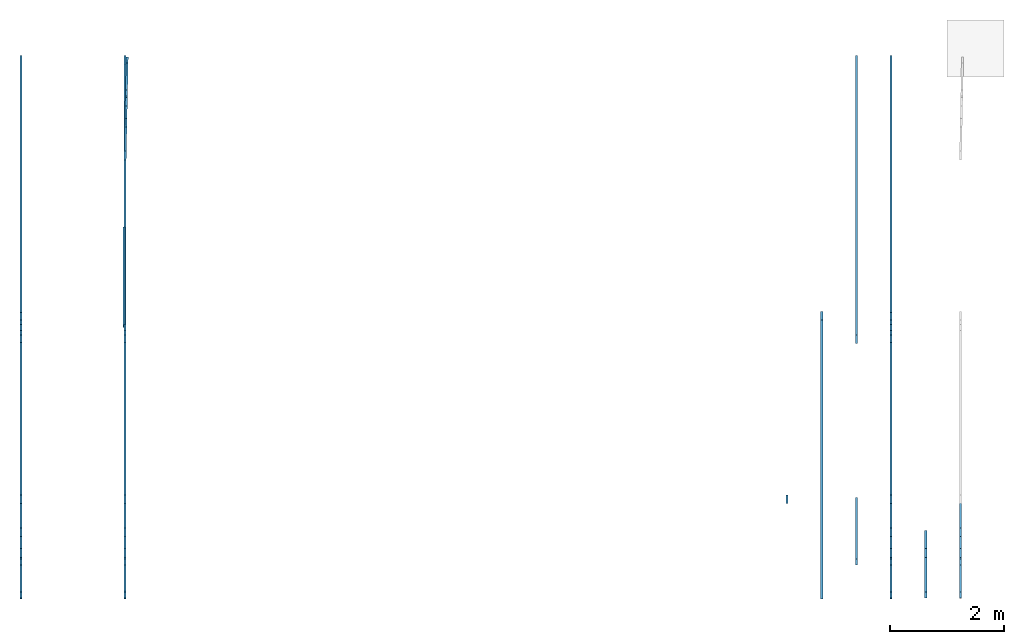
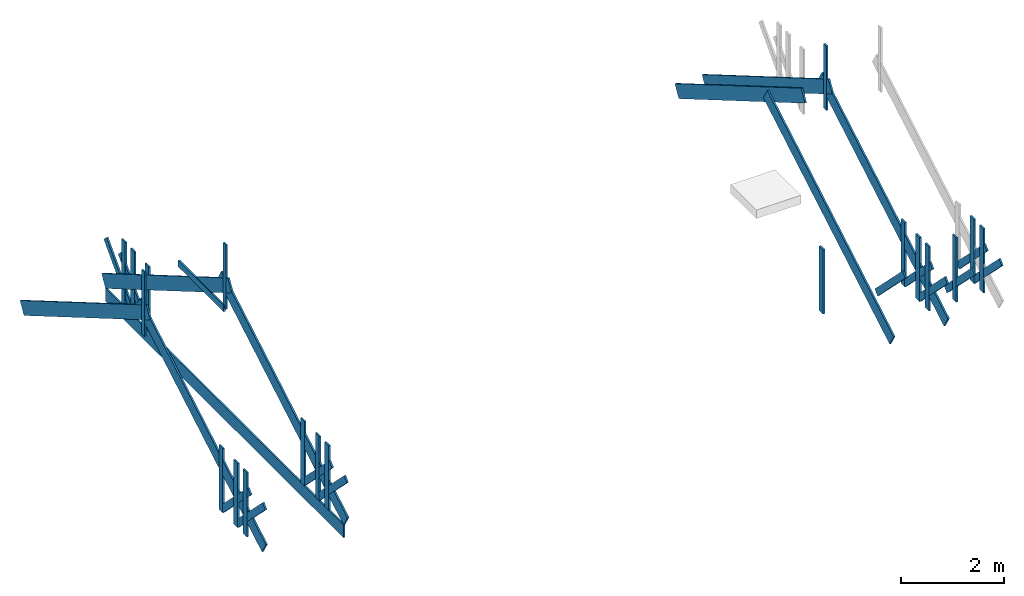
# One storey, part 1 of 2: 44 members, 2 elements without a shape of their own.
"""IFC4 building model written with IfcOpenShell, lengths in inches."""

from ifc_helpers import new_model, entity, si_unit, converted_unit, frame, origin_with_axes, origin_2d_with_axis, place, context, subcontext, project, spatial, indexed_curve, outline, extrude, material, layer, layer_set, layer_usage, type_object, element, aggregate, save


model = new_model("IFC4")

# Units and contexts
model_context = context("Model", 3, precision=1e-05, world=origin_with_axes())
plan_context = context("Plan", 2, precision=1e-05, world=origin_2d_with_axis())
body_context = subcontext(model_context, "Body", "Model", "MODEL_VIEW")
ifc_project = project(units=[converted_unit("PLANEANGLEUNIT", "degree", entity("IfcReal", 0.0174532925199433), si_unit("PLANEANGLEUNIT", "RADIAN"), dimensions=[0, 0, 0, 0, 0, 0, 0]), converted_unit("AREAUNIT", "square inch", entity("IfcReal", 0.0006452), si_unit("AREAUNIT", "SQUARE_METRE"), dimensions=[2, 0, 0, 0, 0, 0, 0]), converted_unit("LENGTHUNIT", "inch", entity("IfcReal", 0.0254), si_unit("LENGTHUNIT", "METRE"), dimensions=[1, 0, 0, 0, 0, 0, 0]), converted_unit("VOLUMEUNIT", "cubic inch", entity("IfcReal", 1.639e-05), si_unit("VOLUMEUNIT", "CUBIC_METRE"), dimensions=[3, 0, 0, 0, 0, 0, 0])], contexts=[model_context, plan_context])

# Site, building, storey
site_placement = place(None, origin_with_axes())
site = spatial("IfcSite", under=ifc_project, at=site_placement)
building_placement = place(site_placement, frame((0.0, 0.0, 109.012492998378), z_axis=(0.0, 0.0, 1.0), x_axis=(1.0, 0.0, 0.0)))
building = spatial("IfcBuilding", under=site, at=building_placement, Name="Building")
storey_placement = place(building_placement, frame((0.0, 0.0, -109.012492998378), z_axis=(0.0, 0.0, 1.0), x_axis=(1.0, 0.0, 0.0)))
storey = spatial("IfcBuildingStorey", under=building, at=storey_placement, Name="Roof")

# Assembly, members
assembly_1_placement = place(storey_placement, frame((53.5001435617762, -175.939563691147, 109.012492998378), z_axis=(0.0, 0.0, 1.0), x_axis=(1.0, 0.0, 0.0)))
assembly_1 = element("IfcElementAssembly", 1, at=assembly_1_placement, inside=storey, Name="QueenTruss", PredefinedType="TRUSS")
ifc_material = material(Name="Default")
ifc_layer_1 = layer(ifc_material, 1.5)
ifc_layer_set_1 = layer_set([ifc_layer_1])
ifc_layer_usage_1 = layer_usage(ifc_layer_set_1, "AXIS2", "POSITIVE", 0.0)
member_type_1 = type_object("IfcMemberType", Name="2x12 wood rafter", PredefinedType="RAFTER", material=ifc_layer_set_1)
member_1_placement = place(assembly_1_placement, frame((1.4999344592958, -181.939526805727, 12.0000013216274), z_axis=(2.75442979535967e-09, -0.504527628421783, 0.863395571708679), x_axis=(5.79808386191871e-07, 0.863395571708679, 0.504527628421783)))
member_1 = element("IfcMember", 2, at=member_1_placement, type_object=member_type_1, material=ifc_layer_usage_1, Name="Member", PredefinedType="NOTDEFINED", context=body_context, shape_type="SweptSolid", body=[
    extrude(outline(indexed_curve([(0.0, 0.0), (0.0, 1.5), (223.635576889592, 1.5), (223.635576889592, 0.0), (0.0, 0.0)], self_intersect=False)), origin_with_axes(), (0.0, 0.0, 1.0), 12.0),
])
ifc_layer_usage_2 = layer_usage(ifc_layer_set_1, "AXIS2", "POSITIVE", 0.0)
member_2_placement = place(assembly_1_placement, frame((3.75462329293799e-05, 181.939563765301, 12.0000013216274), z_axis=(-5.96369176264488e-08, 0.504527628421783, 0.863395571708679), x_axis=(-1.06698792023963e-06, -0.863395571708679, 0.504527628421783)))
member_2 = element("IfcMember", 3, at=member_2_placement, type_object=member_type_1, material=ifc_layer_usage_2, Name="Member", PredefinedType="NOTDEFINED", context=body_context, shape_type="SweptSolid", body=[
    extrude(outline(indexed_curve([(0.0, 0.0), (0.0, 1.5), (223.635576889743, 1.5), (223.635576889743, 0.0), (0.0, 0.0)], self_intersect=False)), origin_with_axes(), (0.0, 0.0, 1.0), 12.0),
])
ifc_layer_usage_3 = layer_usage(ifc_layer_set_1, "AXIS2", "POSITIVE", 0.0)
member_3_placement = place(assembly_1_placement, frame((-71.9998976377052, 181.939563765301, 12.000001321627), z_axis=(-5.96369176264488e-08, 0.504527628421783, 0.863395571708679), x_axis=(-1.06698792023963e-06, -0.863395571708679, 0.504527628421783)))
member_3 = element("IfcMember", 4, at=member_3_placement, type_object=member_type_1, material=ifc_layer_usage_3, Name="Member", PredefinedType="NOTDEFINED", context=body_context, shape_type="SweptSolid", body=[
    extrude(outline(indexed_curve([(0.0, 0.0), (0.0, 1.5), (223.635576889743, 1.5), (223.635576889743, 0.0), (0.0, 0.0)], self_intersect=False)), origin_with_axes(), (0.0, 0.0, 1.0), 12.0),
])
ifc_layer_usage_4 = layer_usage(ifc_layer_set_1, "AXIS2", "POSITIVE", 0.0)
member_4_placement = place(assembly_1_placement, frame((-70.5000007246422, -181.939526805727, 12.000001321627), z_axis=(2.75442979535967e-09, -0.504527628421783, 0.863395571708679), x_axis=(5.79808386191871e-07, 0.863395571708679, 0.504527628421783)))
member_4 = element("IfcMember", 5, at=member_4_placement, type_object=member_type_1, material=ifc_layer_usage_4, Name="Member", PredefinedType="NOTDEFINED", context=body_context, shape_type="SweptSolid", body=[
    extrude(outline(indexed_curve([(0.0, 0.0), (0.0, 1.5), (223.635576889592, 1.5), (223.635576889592, 0.0), (0.0, 0.0)], self_intersect=False)), origin_with_axes(), (0.0, 0.0, 1.0), 12.0),
])

assembly_2_placement = place(storey_placement, origin_with_axes())
assembly_2 = element("IfcElementAssembly", 6, at=assembly_2_placement, inside=storey, Name="Assembly", PredefinedType="NOTDEFINED")
ifc_layer_usage_5 = layer_usage(ifc_layer_set_1, "AXIS2", "POSITIVE", 0.0)
member_5_placement = place(assembly_2_placement, frame((559.49999591497, 6.00000007415381, 121.012494320006), z_axis=(-5.96369176264488e-08, 0.504527628421783, 0.863395571708679), x_axis=(-1.06698792023963e-06, -0.863395571708679, 0.504527628421783)))
member_5 = element("IfcMember", 7, at=member_5_placement, type_object=member_type_1, material=ifc_layer_usage_5, Name="Member", PredefinedType="NOTDEFINED", context=body_context, shape_type="SweptSolid", body=[
    extrude(outline(indexed_curve([(0.0, 0.0), (0.0, 1.5), (223.635576889743, 1.5), (223.635576889743, 0.0), (0.0, 0.0)], self_intersect=False)), origin_with_axes(), (0.0, 0.0, 1.0), 12.0),
])
ifc_layer_usage_6 = layer_usage(ifc_layer_set_1, "AXIS2", "POSITIVE", 0.0)
member_6_placement = place(assembly_2_placement, frame((536.999890184778, -357.879090496874, 121.012494320006), z_axis=(2.75442979535967e-09, -0.504527628421783, 0.863395571708679), x_axis=(5.79808386191871e-07, 0.863395571708679, 0.504527628421783)))
member_6 = element("IfcMember", 8, at=member_6_placement, type_object=member_type_1, material=ifc_layer_usage_6, Name="Member", PredefinedType="NOTDEFINED", context=body_context, shape_type="SweptSolid", body=[
    extrude(outline(indexed_curve([(0.0, 0.0), (0.0, 1.5), (223.635576889592, 1.5), (223.635576889592, 0.0), (0.0, 0.0)], self_intersect=False)), origin_with_axes(), (0.0, 0.0, 1.0), 12.0),
])

# Member
ifc_layer_usage_7 = layer_usage(ifc_layer_set_1, "AXIS2", "POSITIVE", 0.0)
member_7_placement = place(assembly_1_placement, frame((529.999930088914, 181.939563765301, 12.0000013216274), z_axis=(-5.96369176264488e-08, 0.504527628421783, 0.863395571708679), x_axis=(-1.06698792023963e-06, -0.863395571708679, 0.504527628421783)))
member_7 = element("IfcMember", 9, at=member_7_placement, type_object=member_type_1, material=ifc_layer_usage_7, Name="Member", PredefinedType="NOTDEFINED", context=body_context, shape_type="SweptSolid", body=[
    extrude(outline(indexed_curve([(0.0, 0.0), (0.0, 1.5), (223.635576889743, 1.5), (223.635576889743, 0.0), (0.0, 0.0)], self_intersect=False)), origin_with_axes(), (0.0, 0.0, 1.0), 12.0),
])

ifc_layer_usage_8 = layer_usage(ifc_layer_set_1, "AXIS2", "POSITIVE", 0.0)
member_8_placement = place(assembly_1_placement, frame((531.499827001977, -181.939526805727, 12.0000013216274), z_axis=(2.75442979535967e-09, -0.504527628421783, 0.863395571708679), x_axis=(5.79808386191871e-07, 0.863395571708679, 0.504527628421783)))
member_8 = element("IfcMember", 10, at=member_8_placement, type_object=member_type_1, material=ifc_layer_usage_8, Name="Member", PredefinedType="NOTDEFINED", context=body_context, shape_type="SweptSolid", body=[
    extrude(outline(indexed_curve([(0.0, 0.0), (0.0, 1.5), (223.635576889592, 1.5), (223.635576889592, 0.0), (0.0, 0.0)], self_intersect=False)), origin_with_axes(), (0.0, 0.0, 1.0), 12.0),
])

ifc_layer_2 = layer(ifc_material, 1.5, ventilated=False, Name="2x4 wood member")
ifc_layer_set_2 = layer_set([ifc_layer_2], Name="2x4 wood member")
ifc_layer_usage_9 = layer_usage(ifc_layer_set_2, "AXIS2", "POSITIVE", 0.0)
member_type_2 = type_object("IfcMemberType", Name="2x4 wood member", PredefinedType="NOTDEFINED", material=ifc_layer_set_2)
member_9_placement = place(assembly_1_placement, frame((1.50008464422752, 2.00001273568221, 104.000014582957), z_axis=(4.37113882867379e-08, -1.0, -8.51092183247427e-15), x_axis=(1.94707183709397e-07, 0.0, 1.0)))
member_9 = element("IfcMember", 11, at=member_9_placement, type_object=member_type_2, material=ifc_layer_usage_9, Name="Member", PredefinedType="NOTDEFINED", context=body_context, shape_type="SweptSolid", body=[
    extrude(outline(indexed_curve([(0.0, 0.0), (0.0, 1.5), (60.0000067531971, 1.5), (60.0000067531971, 0.0), (0.0, 0.0)], self_intersect=False)), origin_with_axes(), (0.0, 0.0, 1.0), 4.0),
])

ifc_layer_usage_10 = layer_usage(ifc_layer_set_2, "AXIS2", "POSITIVE", 0.0)
member_10_placement = place(assembly_1_placement, frame((-70.4998505397102, 2.00001273568151, 104.000014582957), z_axis=(4.37113882867379e-08, -1.0, -8.51092183247427e-15), x_axis=(1.94707183709397e-07, 0.0, 1.0)))
member_10 = element("IfcMember", 12, at=member_10_placement, type_object=member_type_2, material=ifc_layer_usage_10, Name="Member", PredefinedType="NOTDEFINED", context=body_context, shape_type="SweptSolid", body=[
    extrude(outline(indexed_curve([(0.0, 0.0), (0.0, 1.5), (60.0000067531971, 1.5), (60.0000067531971, 0.0), (0.0, 0.0)], self_intersect=False)), origin_with_axes(), (0.0, 0.0, 1.0), 4.0),
])

ifc_layer_usage_11 = layer_usage(ifc_layer_set_2, "AXIS2", "POSITIVE", 0.0)
member_11_placement = place(assembly_2_placement, frame((-16.9997069779343, -173.939550955465, 213.012507581335), z_axis=(4.37113882867379e-08, -1.0, -8.51092183247427e-15), x_axis=(1.94707183709397e-07, 0.0, 1.0)))
member_11 = element("IfcMember", 13, at=member_11_placement, type_object=member_type_2, material=ifc_layer_usage_11, Name="Member", PredefinedType="NOTDEFINED", context=body_context, shape_type="SweptSolid", body=[
    extrude(outline(indexed_curve([(0.0, 0.0), (0.0, 1.5), (60.0000067531971, 1.5), (60.0000067531971, 0.0), (0.0, 0.0)], self_intersect=False)), origin_with_axes(), (0.0, 0.0, 1.0), 4.0),
])

ifc_layer_usage_12 = layer_usage(ifc_layer_set_2, "AXIS2", "POSITIVE", 0.0)
member_12_placement = place(assembly_1_placement, frame((531.499977186909, 2.00001273568221, 104.000014582957), z_axis=(4.37113882867379e-08, -1.0, -8.51092183247427e-15), x_axis=(1.94707183709397e-07, 0.0, 1.0)))
member_12 = element("IfcMember", 14, at=member_12_placement, type_object=member_type_2, material=ifc_layer_usage_12, Name="Member", PredefinedType="NOTDEFINED", context=body_context, shape_type="SweptSolid", body=[
    extrude(outline(indexed_curve([(0.0, 0.0), (0.0, 1.5), (60.0000067531971, 1.5), (60.0000067531971, 0.0), (0.0, 0.0)], self_intersect=False)), origin_with_axes(), (0.0, 0.0, 1.0), 4.0),
])

ifc_layer_3 = layer(ifc_material, 1.5, Name="2x6 wood member")
ifc_layer_set_3 = layer_set([ifc_layer_3])
ifc_layer_usage_13 = layer_usage(ifc_layer_set_3, "AXIS2", "POSITIVE", 0.0)
member_type_3 = type_object("IfcMemberType", Name="2x6 wood member", PredefinedType="NOTDEFINED", material=ifc_layer_set_3)
member_13_placement = place(assembly_1_placement, frame((1.49985936682994, -117.696889742153, 16.2426505501815), z_axis=(9.1863917361934e-08, -0.707106709480286, -0.707106709480286), x_axis=(2.83789688637626e-07, -0.707106709480286, 0.707106709480286)))
member_13 = element("IfcMember", 15, at=member_13_placement, type_object=member_type_3, material=ifc_layer_usage_13, Name="Member", PredefinedType="NOTDEFINED", context=body_context, shape_type="SweptSolid", body=[
    extrude(outline(indexed_curve([(0.0, 0.0), (0.0, 1.5), (60.0000067531971, 1.5), (60.0000067531971, 0.0), (0.0, 0.0)], self_intersect=False)), origin_with_axes(), (0.0, 0.0, 1.0), 6.0),
])

ifc_layer_usage_14 = layer_usage(ifc_layer_set_3, "AXIS2", "POSITIVE", 0.0)
member_14_placement = place(assembly_1_placement, frame((1.4999344592958, -115.939519536777, 12.0000013216274), z_axis=(4.37113882867379e-08, -1.0, -8.51092183247427e-15), x_axis=(1.94707183709397e-07, 0.0, 1.0)))
member_14 = element("IfcMember", 16, at=member_14_placement, type_object=member_type_3, material=ifc_layer_usage_14, Name="Member", PredefinedType="NOTDEFINED", context=body_context, shape_type="SweptSolid", body=[
    extrude(outline(indexed_curve([(0.0, 0.0), (0.0, 1.5), (60.0000067531971, 1.5), (60.0000067531971, 0.0), (0.0, 0.0)], self_intersect=False)), origin_with_axes(), (0.0, 0.0, 1.0), 6.0),
])

ifc_layer_usage_15 = layer_usage(ifc_layer_set_3, "AXIS2", "POSITIVE", 0.0)
member_15_placement = place(assembly_1_placement, frame((1.4999344592958, -138.713487489956, 12.0000013216274), z_axis=(4.37113882867379e-08, -1.0, -8.51092183247427e-15), x_axis=(1.94707183709397e-07, 0.0, 1.0)))
member_15 = element("IfcMember", 17, at=member_15_placement, type_object=member_type_3, material=ifc_layer_usage_15, Name="Member", PredefinedType="NOTDEFINED", context=body_context, shape_type="SweptSolid", body=[
    extrude(outline(indexed_curve([(0.0, 0.0), (0.0, 1.5), (60.0000067531971, 1.5), (60.0000067531971, 0.0), (0.0, 0.0)], self_intersect=False)), origin_with_axes(), (0.0, 0.0, 1.0), 6.0),
])

ifc_layer_usage_16 = layer_usage(ifc_layer_set_3, "AXIS2", "POSITIVE", 0.0)
member_16_placement = place(assembly_1_placement, frame((1.49985936682994, -140.470838922215, 16.2426411636232), z_axis=(6.26377456569571e-08, -0.707106709480286, -0.707106709480286), x_axis=(1.99495985953035e-07, -0.707106709480286, 0.707106709480286)))
member_16 = element("IfcMember", 18, at=member_16_placement, type_object=member_type_3, material=ifc_layer_usage_16, Name="Member", PredefinedType="NOTDEFINED", context=body_context, shape_type="SweptSolid", body=[
    extrude(outline(indexed_curve([(0.0, 0.0), (0.0, 1.5), (60.0000067531971, 1.5), (60.0000067531971, 0.0), (0.0, 0.0)], self_intersect=False)), origin_with_axes(), (0.0, 0.0, 1.0), 6.0),
])

ifc_layer_usage_17 = layer_usage(ifc_layer_set_3, "AXIS2", "POSITIVE", 0.0)
member_17_placement = place(assembly_1_placement, frame((1.4999344592958, -153.087799943338, 12.0000013216274), z_axis=(4.37113882867379e-08, -1.0, -8.51092183247427e-15), x_axis=(1.94707183709397e-07, 0.0, 1.0)))
member_17 = element("IfcMember", 19, at=member_17_placement, type_object=member_type_3, material=ifc_layer_usage_17, Name="Member", PredefinedType="NOTDEFINED", context=body_context, shape_type="SweptSolid", body=[
    extrude(outline(indexed_curve([(0.0, 0.0), (0.0, 1.5), (60.0000067531971, 1.5), (60.0000067531971, 0.0), (0.0, 0.0)], self_intersect=False)), origin_with_axes(), (0.0, 0.0, 1.0), 6.0),
])

ifc_layer_usage_18 = layer_usage(ifc_layer_set_3, "AXIS2", "POSITIVE", 0.0)
member_18_placement = place(assembly_1_placement, frame((0.749835817832646, 1.877311646469e-05, 100.766833372942), z_axis=(0.0, 0.0, 1.0), x_axis=(3.13916473260178e-07, 1.0, 0.0)))
member_18 = element("IfcMember", 20, at=member_18_placement, type_object=member_type_3, material=ifc_layer_usage_18, Name="Member", PredefinedType="NOTDEFINED", context=body_context, shape_type="SweptSolid", body=[
    extrude(outline(indexed_curve([(0.0, 0.0), (0.0, 1.5), (69.5363184959885, 1.5), (69.5363184959885, 0.0), (0.0, 0.0)], self_intersect=False)), origin_with_axes(), (0.0, 0.0, 1.0), 6.0),
])

ifc_layer_usage_19 = layer_usage(ifc_layer_set_3, "AXIS2", "POSITIVE", 0.0)
member_19_placement = place(assembly_1_placement, frame((0.0360819298451341, 117.705422123586, 16.2426505501815), z_axis=(0.01430035661906, 0.706962108612061, -0.707106709480286), x_axis=(0.0142999459058046, 0.706962108612061, 0.707106709480286)))
member_19 = element("IfcMember", 21, at=member_19_placement, type_object=member_type_3, material=ifc_layer_usage_19, Name="Member", PredefinedType="NOTDEFINED", context=body_context, shape_type="SweptSolid", body=[
    extrude(outline(indexed_curve([(0.0, 0.0), (0.0, 1.5), (60.0000067531971, 1.5), (60.0000067531971, 0.0), (0.0, 0.0)], self_intersect=False)), origin_with_axes(), (0.0, 0.0, 1.0), 6.0),
])

ifc_layer_usage_20 = layer_usage(ifc_layer_set_3, "AXIS2", "POSITIVE", 0.0)
member_20_placement = place(assembly_1_placement, frame((0.000413008562223179, 115.948417993981, 12.0000013216274), z_axis=(0.0202241335064173, 0.999795496463776, -3.93778432083991e-09), x_axis=(1.94707183709397e-07, 0.0, 1.0)))
member_20 = element("IfcMember", 22, at=member_20_placement, type_object=member_type_3, material=ifc_layer_usage_20, Name="Member", PredefinedType="NOTDEFINED", context=body_context, shape_type="SweptSolid", body=[
    extrude(outline(indexed_curve([(0.0, 0.0), (0.0, 1.5), (60.0000067531971, 1.5), (60.0000067531971, 0.0), (0.0, 0.0)], self_intersect=False)), origin_with_axes(), (0.0, 0.0, 1.0), 6.0),
])

ifc_layer_usage_21 = layer_usage(ifc_layer_set_3, "AXIS2", "POSITIVE", 0.0)
member_21_placement = place(assembly_1_placement, frame((0.461030194139856, 138.717718481079, 12.0000013216274), z_axis=(0.0202241335064173, 0.999795496463776, -3.93778432083991e-09), x_axis=(1.94707183709397e-07, 0.0, 1.0)))
member_21 = element("IfcMember", 23, at=member_21_placement, type_object=member_type_3, material=ifc_layer_usage_21, Name="Member", PredefinedType="NOTDEFINED", context=body_context, shape_type="SweptSolid", body=[
    extrude(outline(indexed_curve([(0.0, 0.0), (0.0, 1.5), (60.0000067531971, 1.5), (60.0000067531971, 0.0), (0.0, 0.0)], self_intersect=False)), origin_with_axes(), (0.0, 0.0, 1.0), 6.0),
])

ifc_layer_usage_22 = layer_usage(ifc_layer_set_3, "AXIS2", "POSITIVE", 0.0)
member_22_placement = place(assembly_1_placement, frame((0.496624022956908, 140.474713224126, 16.2426411636232), z_axis=(0.0143004665151238, 0.706962108612061, -0.707106709480286), x_axis=(0.0142999459058046, 0.706962108612061, 0.707106709480286)))
member_22 = element("IfcMember", 24, at=member_22_placement, type_object=member_type_3, material=ifc_layer_usage_22, Name="Member", PredefinedType="NOTDEFINED", context=body_context, shape_type="SweptSolid", body=[
    extrude(outline(indexed_curve([(0.0, 0.0), (0.0, 1.5), (60.0000067531971, 1.5), (60.0000067531971, 0.0), (0.0, 0.0)], self_intersect=False)), origin_with_axes(), (0.0, 0.0, 1.0), 6.0),
])

ifc_layer_usage_23 = layer_usage(ifc_layer_set_3, "AXIS2", "POSITIVE", 0.0)
member_23_placement = place(assembly_1_placement, frame((0.751713129479115, 153.089092941735, 12.0000013216274), z_axis=(0.0202241335064173, 0.999795496463776, -3.93778432083991e-09), x_axis=(1.94707183709397e-07, 0.0, 1.0)))
member_23 = element("IfcMember", 25, at=member_23_placement, type_object=member_type_3, material=ifc_layer_usage_23, Name="Member", PredefinedType="NOTDEFINED", context=body_context, shape_type="SweptSolid", body=[
    extrude(outline(indexed_curve([(0.0, 0.0), (0.0, 1.5), (60.0000067531971, 1.5), (60.0000067531971, 0.0), (0.0, 0.0)], self_intersect=False)), origin_with_axes(), (0.0, 0.0, 1.0), 6.0),
])

# Members
ifc_layer_usage_24 = layer_usage(ifc_layer_set_3, "AXIS2", "POSITIVE", 0.0)
member_24_placement = place(storey_placement, frame((632.999900757797, -314.653051181102, 121.012494320006), z_axis=(4.37113882867379e-08, -1.0, -8.51092183247427e-15), x_axis=(1.94707183709397e-07, 0.0, 1.0)))
element("IfcMember", 26, at=member_24_placement, inside=storey, type_object=member_type_3, material=ifc_layer_usage_24, Name="Member", PredefinedType="NOTDEFINED", context=body_context, shape_type="SweptSolid", body=[
    extrude(outline(indexed_curve([(0.0, 0.0), (0.0, 1.5), (60.0000067531971, 1.5), (60.0000067531971, 0.0), (0.0, 0.0)], self_intersect=False)), origin_with_axes(), (0.0, 0.0, 1.0), 6.0),
])
ifc_layer_usage_25 = layer_usage(ifc_layer_set_3, "AXIS2", "POSITIVE", 0.0)
member_25_placement = place(storey_placement, frame((632.999825665331, -316.410402613362, 125.255134162002), z_axis=(6.26377456569571e-08, -0.707106709480286, -0.707106709480286), x_axis=(1.99495985953035e-07, -0.707106709480286, 0.707106709480286)))
element("IfcMember", 27, at=member_25_placement, inside=storey, type_object=member_type_3, material=ifc_layer_usage_25, Name="Member", PredefinedType="NOTDEFINED", context=body_context, shape_type="SweptSolid", body=[
    extrude(outline(indexed_curve([(0.0, 0.0), (0.0, 1.5), (60.0000067531971, 1.5), (60.0000067531971, 0.0), (0.0, 0.0)], self_intersect=False)), origin_with_axes(), (0.0, 0.0, 1.0), 6.0),
])
ifc_layer_usage_26 = layer_usage(ifc_layer_set_3, "AXIS2", "POSITIVE", 0.0)
member_26_placement = place(storey_placement, frame((632.999900757797, -329.027363634485, 121.012494320006), z_axis=(4.37113882867379e-08, -1.0, -8.51092183247427e-15), x_axis=(1.94707183709397e-07, 0.0, 1.0)))
element("IfcMember", 28, at=member_26_placement, inside=storey, type_object=member_type_3, material=ifc_layer_usage_26, Name="Member", PredefinedType="NOTDEFINED", context=body_context, shape_type="SweptSolid", body=[
    extrude(outline(indexed_curve([(0.0, 0.0), (0.0, 1.5), (60.0000067531971, 1.5), (60.0000067531971, 0.0), (0.0, 0.0)], self_intersect=False)), origin_with_axes(), (0.0, 0.0, 1.0), 6.0),
])
ifc_layer_usage_27 = layer_usage(ifc_layer_set_3, "AXIS2", "POSITIVE", 0.0)
member_27_placement = place(storey_placement, frame((632.999825665331, -293.6364534333, 125.25514354856), z_axis=(9.1863917361934e-08, -0.707106709480286, -0.707106709480286), x_axis=(2.83789688637626e-07, -0.707106709480286, 0.707106709480286)))
element("IfcMember", 29, at=member_27_placement, inside=storey, type_object=member_type_3, material=ifc_layer_usage_27, Name="Member", PredefinedType="NOTDEFINED", context=body_context, shape_type="SweptSolid", body=[
    extrude(outline(indexed_curve([(0.0, 0.0), (0.0, 1.5), (60.0000067531971, 1.5), (60.0000067531971, 0.0), (0.0, 0.0)], self_intersect=False)), origin_with_axes(), (0.0, 0.0, 1.0), 6.0),
])
ifc_layer_usage_28 = layer_usage(ifc_layer_set_3, "AXIS2", "POSITIVE", 0.0)
member_28_placement = place(storey_placement, frame((632.999900757797, -314.653051181102, 121.012494320006), z_axis=(4.37113882867379e-08, -1.0, -8.51092183247427e-15), x_axis=(1.94707183709397e-07, 0.0, 1.0)))
element("IfcMember", 30, at=member_28_placement, inside=storey, type_object=member_type_3, material=ifc_layer_usage_28, Name="Member", PredefinedType="NOTDEFINED", context=body_context, shape_type="SweptSolid", body=[
    extrude(outline(indexed_curve([(0.0, 0.0), (0.0, 1.5), (60.0000067531971, 1.5), (60.0000067531971, 0.0), (0.0, 0.0)], self_intersect=False)), origin_with_axes(), (0.0, 0.0, 1.0), 6.0),
])

# Member
ifc_layer_usage_29 = layer_usage(ifc_layer_set_3, "AXIS2", "POSITIVE", 0.0)
member_29_placement = place(assembly_1_placement, frame((-70.5000007246422, -115.939519536777, 12.000001321627), z_axis=(4.37113882867379e-08, -1.0, -8.51092183247427e-15), x_axis=(1.94707183709397e-07, 0.0, 1.0)))
member_29 = element("IfcMember", 31, at=member_29_placement, type_object=member_type_3, material=ifc_layer_usage_29, Name="Member", PredefinedType="NOTDEFINED", context=body_context, shape_type="SweptSolid", body=[
    extrude(outline(indexed_curve([(0.0, 0.0), (0.0, 1.5), (60.0000067531971, 1.5), (60.0000067531971, 0.0), (0.0, 0.0)], self_intersect=False)), origin_with_axes(), (0.0, 0.0, 1.0), 6.0),
])

ifc_layer_usage_30 = layer_usage(ifc_layer_set_3, "AXIS2", "POSITIVE", 0.0)
member_30_placement = place(assembly_1_placement, frame((-70.5000007246422, -138.713487489955, 12.000001321627), z_axis=(4.37113882867379e-08, -1.0, -8.51092183247427e-15), x_axis=(1.94707183709397e-07, 0.0, 1.0)))
member_30 = element("IfcMember", 32, at=member_30_placement, type_object=member_type_3, material=ifc_layer_usage_30, Name="Member", PredefinedType="NOTDEFINED", context=body_context, shape_type="SweptSolid", body=[
    extrude(outline(indexed_curve([(0.0, 0.0), (0.0, 1.5), (60.0000067531971, 1.5), (60.0000067531971, 0.0), (0.0, 0.0)], self_intersect=False)), origin_with_axes(), (0.0, 0.0, 1.0), 6.0),
])

ifc_layer_usage_31 = layer_usage(ifc_layer_set_3, "AXIS2", "POSITIVE", 0.0)
member_31_placement = place(assembly_1_placement, frame((-70.5000758171083, -140.470838922215, 16.242641163623), z_axis=(6.26377456569571e-08, -0.707106709480286, -0.707106709480286), x_axis=(1.99495985953035e-07, -0.707106709480286, 0.707106709480286)))
member_31 = element("IfcMember", 33, at=member_31_placement, type_object=member_type_3, material=ifc_layer_usage_31, Name="Member", PredefinedType="NOTDEFINED", context=body_context, shape_type="SweptSolid", body=[
    extrude(outline(indexed_curve([(0.0, 0.0), (0.0, 1.5), (60.0000067531971, 1.5), (60.0000067531971, 0.0), (0.0, 0.0)], self_intersect=False)), origin_with_axes(), (0.0, 0.0, 1.0), 6.0),
])

ifc_layer_usage_32 = layer_usage(ifc_layer_set_3, "AXIS2", "POSITIVE", 0.0)
member_32_placement = place(assembly_1_placement, frame((-70.5000007246422, -153.087799943338, 12.000001321627), z_axis=(4.37113882867379e-08, -1.0, -8.51092183247427e-15), x_axis=(1.94707183709397e-07, 0.0, 1.0)))
member_32 = element("IfcMember", 34, at=member_32_placement, type_object=member_type_3, material=ifc_layer_usage_32, Name="Member", PredefinedType="NOTDEFINED", context=body_context, shape_type="SweptSolid", body=[
    extrude(outline(indexed_curve([(0.0, 0.0), (0.0, 1.5), (60.0000067531971, 1.5), (60.0000067531971, 0.0), (0.0, 0.0)], self_intersect=False)), origin_with_axes(), (0.0, 0.0, 1.0), 6.0),
])

ifc_layer_usage_33 = layer_usage(ifc_layer_set_3, "AXIS2", "POSITIVE", 0.0)
member_33_placement = place(assembly_1_placement, frame((-70.5000758171083, -117.696889742153, 16.242650550181), z_axis=(9.1863917361934e-08, -0.707106709480286, -0.707106709480286), x_axis=(2.83789688637626e-07, -0.707106709480286, 0.707106709480286)))
member_33 = element("IfcMember", 35, at=member_33_placement, type_object=member_type_3, material=ifc_layer_usage_33, Name="Member", PredefinedType="NOTDEFINED", context=body_context, shape_type="SweptSolid", body=[
    extrude(outline(indexed_curve([(0.0, 0.0), (0.0, 1.5), (60.0000067531971, 1.5), (60.0000067531971, 0.0), (0.0, 0.0)], self_intersect=False)), origin_with_axes(), (0.0, 0.0, 1.0), 6.0),
])

ifc_layer_usage_34 = layer_usage(ifc_layer_set_3, "AXIS2", "POSITIVE", 0.0)
member_34_placement = place(assembly_2_placement, frame((512.999887541523, -291.879083227924, 121.012494320006), z_axis=(4.37113882867379e-08, -1.0, -8.51092183247427e-15), x_axis=(1.94707183709397e-07, 0.0, 1.0)))
member_34 = element("IfcMember", 36, at=member_34_placement, type_object=member_type_3, material=ifc_layer_usage_34, Name="Member", PredefinedType="NOTDEFINED", context=body_context, shape_type="SweptSolid", body=[
    extrude(outline(indexed_curve([(0.0, 0.0), (0.0, 1.5), (60.0000067531971, 1.5), (60.0000067531971, 0.0), (0.0, 0.0)], self_intersect=False)), origin_with_axes(), (0.0, 0.0, 1.0), 6.0),
])

ifc_layer_usage_35 = layer_usage(ifc_layer_set_3, "AXIS2", "POSITIVE", 0.0)
member_35_placement = place(assembly_2_placement, frame((-16.9998571628661, -314.653051181102, 121.012494320006), z_axis=(4.37113882867379e-08, -1.0, -8.51092183247427e-15), x_axis=(1.94707183709397e-07, 0.0, 1.0)))
member_35 = element("IfcMember", 37, at=member_35_placement, type_object=member_type_3, material=ifc_layer_usage_35, Name="Member", PredefinedType="NOTDEFINED", context=body_context, shape_type="SweptSolid", body=[
    extrude(outline(indexed_curve([(0.0, 0.0), (0.0, 1.5), (60.0000067531971, 1.5), (60.0000067531971, 0.0), (0.0, 0.0)], self_intersect=False)), origin_with_axes(), (0.0, 0.0, 1.0), 6.0),
])

ifc_layer_usage_36 = layer_usage(ifc_layer_set_3, "AXIS2", "POSITIVE", 0.0)
member_36_placement = place(assembly_1_placement, frame((555.4996794603, -140.470838922215, 16.2426411636227), z_axis=(6.26377456569571e-08, -0.707106709480286, -0.707106709480286), x_axis=(1.99495985953035e-07, -0.707106709480286, 0.707106709480286)))
member_36 = element("IfcMember", 38, at=member_36_placement, type_object=member_type_3, material=ifc_layer_usage_36, Name="Member", PredefinedType="NOTDEFINED", context=body_context, shape_type="SweptSolid", body=[
    extrude(outline(indexed_curve([(0.0, 0.0), (0.0, 1.5), (60.0000067531971, 1.5), (60.0000067531971, 0.0), (0.0, 0.0)], self_intersect=False)), origin_with_axes(), (0.0, 0.0, 1.0), 6.0),
])

ifc_layer_usage_37 = layer_usage(ifc_layer_set_3, "AXIS2", "POSITIVE", 0.0)
member_37_placement = place(assembly_1_placement, frame((555.499754552766, -153.087799943338, 12.0000013216269), z_axis=(4.37113882867379e-08, -1.0, -8.51092183247427e-15), x_axis=(1.94707183709397e-07, 0.0, 1.0)))
member_37 = element("IfcMember", 39, at=member_37_placement, type_object=member_type_3, material=ifc_layer_usage_37, Name="Member", PredefinedType="NOTDEFINED", context=body_context, shape_type="SweptSolid", body=[
    extrude(outline(indexed_curve([(0.0, 0.0), (0.0, 1.5), (60.0000067531971, 1.5), (60.0000067531971, 0.0), (0.0, 0.0)], self_intersect=False)), origin_with_axes(), (0.0, 0.0, 1.0), 6.0),
])

ifc_layer_usage_38 = layer_usage(ifc_layer_set_3, "AXIS2", "POSITIVE", 0.0)
member_38_placement = place(assembly_2_placement, frame((560.999817735567, -293.6364534333, 125.25514354856), z_axis=(9.1863917361934e-08, -0.707106709480286, -0.707106709480286), x_axis=(2.83789688637626e-07, -0.707106709480286, 0.707106709480286)))
member_38 = element("IfcMember", 40, at=member_38_placement, type_object=member_type_3, material=ifc_layer_usage_38, Name="Member", PredefinedType="NOTDEFINED", context=body_context, shape_type="SweptSolid", body=[
    extrude(outline(indexed_curve([(0.0, 0.0), (0.0, 1.5), (60.0000067531971, 1.5), (60.0000067531971, 0.0), (0.0, 0.0)], self_intersect=False)), origin_with_axes(), (0.0, 0.0, 1.0), 6.0),
])

aggregate(assembly_2, [member_11, member_5, member_6, member_34, member_35, member_38])

ifc_layer_usage_39 = layer_usage(ifc_layer_set_3, "AXIS2", "POSITIVE", 0.0)
member_39_placement = place(assembly_1_placement, frame((531.499827001977, -115.939519536777, 12.0000013216274), z_axis=(4.37113882867379e-08, -1.0, -8.51092183247427e-15), x_axis=(1.94707183709397e-07, 0.0, 1.0)))
member_39 = element("IfcMember", 41, at=member_39_placement, type_object=member_type_3, material=ifc_layer_usage_39, Name="Member", PredefinedType="NOTDEFINED", context=body_context, shape_type="SweptSolid", body=[
    extrude(outline(indexed_curve([(0.0, 0.0), (0.0, 1.5), (60.0000067531971, 1.5), (60.0000067531971, 0.0), (0.0, 0.0)], self_intersect=False)), origin_with_axes(), (0.0, 0.0, 1.0), 6.0),
])

ifc_layer_usage_40 = layer_usage(ifc_layer_set_3, "AXIS2", "POSITIVE", 0.0)
member_40_placement = place(assembly_1_placement, frame((531.499827001977, -138.713487489956, 12.0000013216274), z_axis=(4.37113882867379e-08, -1.0, -8.51092183247427e-15), x_axis=(1.94707183709397e-07, 0.0, 1.0)))
member_40 = element("IfcMember", 42, at=member_40_placement, type_object=member_type_3, material=ifc_layer_usage_40, Name="Member", PredefinedType="NOTDEFINED", context=body_context, shape_type="SweptSolid", body=[
    extrude(outline(indexed_curve([(0.0, 0.0), (0.0, 1.5), (60.0000067531971, 1.5), (60.0000067531971, 0.0), (0.0, 0.0)], self_intersect=False)), origin_with_axes(), (0.0, 0.0, 1.0), 6.0),
])

ifc_layer_usage_41 = layer_usage(ifc_layer_set_3, "AXIS2", "POSITIVE", 0.0)
member_41_placement = place(assembly_1_placement, frame((531.499751909511, -140.470838922215, 16.2426411636232), z_axis=(6.26377456569571e-08, -0.707106709480286, -0.707106709480286), x_axis=(1.99495985953035e-07, -0.707106709480286, 0.707106709480286)))
member_41 = element("IfcMember", 43, at=member_41_placement, type_object=member_type_3, material=ifc_layer_usage_41, Name="Member", PredefinedType="NOTDEFINED", context=body_context, shape_type="SweptSolid", body=[
    extrude(outline(indexed_curve([(0.0, 0.0), (0.0, 1.5), (60.0000067531971, 1.5), (60.0000067531971, 0.0), (0.0, 0.0)], self_intersect=False)), origin_with_axes(), (0.0, 0.0, 1.0), 6.0),
])

ifc_layer_usage_42 = layer_usage(ifc_layer_set_3, "AXIS2", "POSITIVE", 0.0)
member_42_placement = place(assembly_1_placement, frame((531.499827001977, -153.087799943338, 12.0000013216274), z_axis=(4.37113882867379e-08, -1.0, -8.51092183247427e-15), x_axis=(1.94707183709397e-07, 0.0, 1.0)))
member_42 = element("IfcMember", 44, at=member_42_placement, type_object=member_type_3, material=ifc_layer_usage_42, Name="Member", PredefinedType="NOTDEFINED", context=body_context, shape_type="SweptSolid", body=[
    extrude(outline(indexed_curve([(0.0, 0.0), (0.0, 1.5), (60.0000067531971, 1.5), (60.0000067531971, 0.0), (0.0, 0.0)], self_intersect=False)), origin_with_axes(), (0.0, 0.0, 1.0), 6.0),
])

ifc_layer_usage_43 = layer_usage(ifc_layer_set_3, "AXIS2", "POSITIVE", 0.0)
member_43_placement = place(assembly_1_placement, frame((531.499751909511, -117.696889742153, 16.2426505501815), z_axis=(9.1863917361934e-08, -0.707106709480286, -0.707106709480286), x_axis=(2.83789688637626e-07, -0.707106709480286, 0.707106709480286)))
member_43 = element("IfcMember", 45, at=member_43_placement, type_object=member_type_3, material=ifc_layer_usage_43, Name="Member", PredefinedType="NOTDEFINED", context=body_context, shape_type="SweptSolid", body=[
    extrude(outline(indexed_curve([(0.0, 0.0), (0.0, 1.5), (60.0000067531971, 1.5), (60.0000067531971, 0.0), (0.0, 0.0)], self_intersect=False)), origin_with_axes(), (0.0, 0.0, 1.0), 6.0),
])

ifc_layer_4 = layer(ifc_material, 1.5, Name="2x12 wood chord")
ifc_layer_set_4 = layer_set([ifc_layer_4], Name="2x12 wood chord")
ifc_layer_usage_44 = layer_usage(ifc_layer_set_4, "AXIS2", "POSITIVE", 0.0)
member_type_4 = type_object("IfcMemberType", Name="2x12 wood chord", PredefinedType="CHORD", material=ifc_layer_set_4)
member_44_placement = place(assembly_1_placement, frame((1.4999344592958, -181.939526805727, 0.0), z_axis=(0.0, 0.0, 1.0), x_axis=(3.13916473260178e-07, 1.0, 0.0)))
member_44 = element("IfcMember", 46, at=member_44_placement, type_object=member_type_4, material=ifc_layer_usage_44, Name="Member", PredefinedType="NOTDEFINED", context=body_context, shape_type="SweptSolid", body=[
    extrude(outline(indexed_curve([(0.0, 0.0), (0.0, 1.5), (363.879055554429, 1.5), (363.879055554429, 0.0), (0.0, 0.0)], self_intersect=False)), origin_with_axes(), (0.0, 0.0, 1.0), 12.0),
])

aggregate(assembly_1, [member_1, member_2, member_13, member_14, member_15, member_16, member_17, member_18, member_9, member_19, member_20, member_21, member_22, member_23, member_44, member_10, member_3, member_4, member_29, member_30, member_31, member_32, member_33, member_36, member_37, member_12, member_7, member_8, member_39, member_40, member_41, member_42, member_43])

save(model, "model.ifc")
